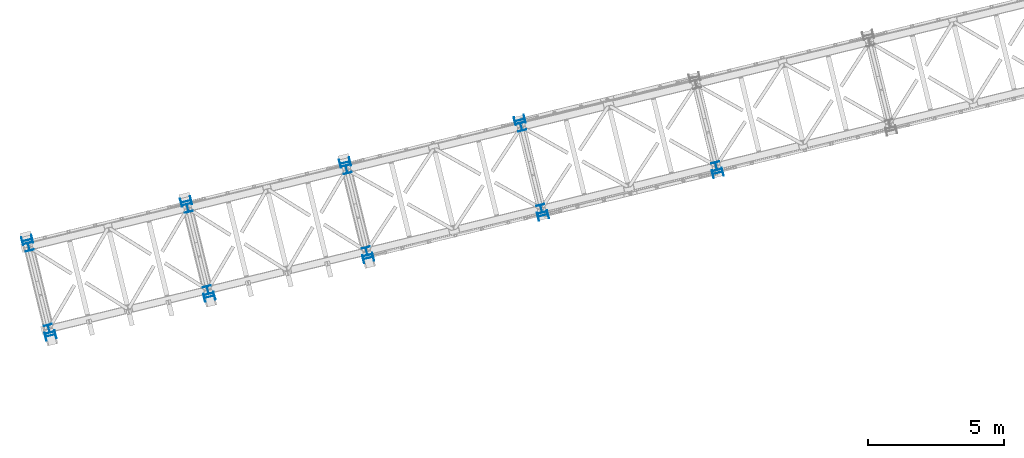
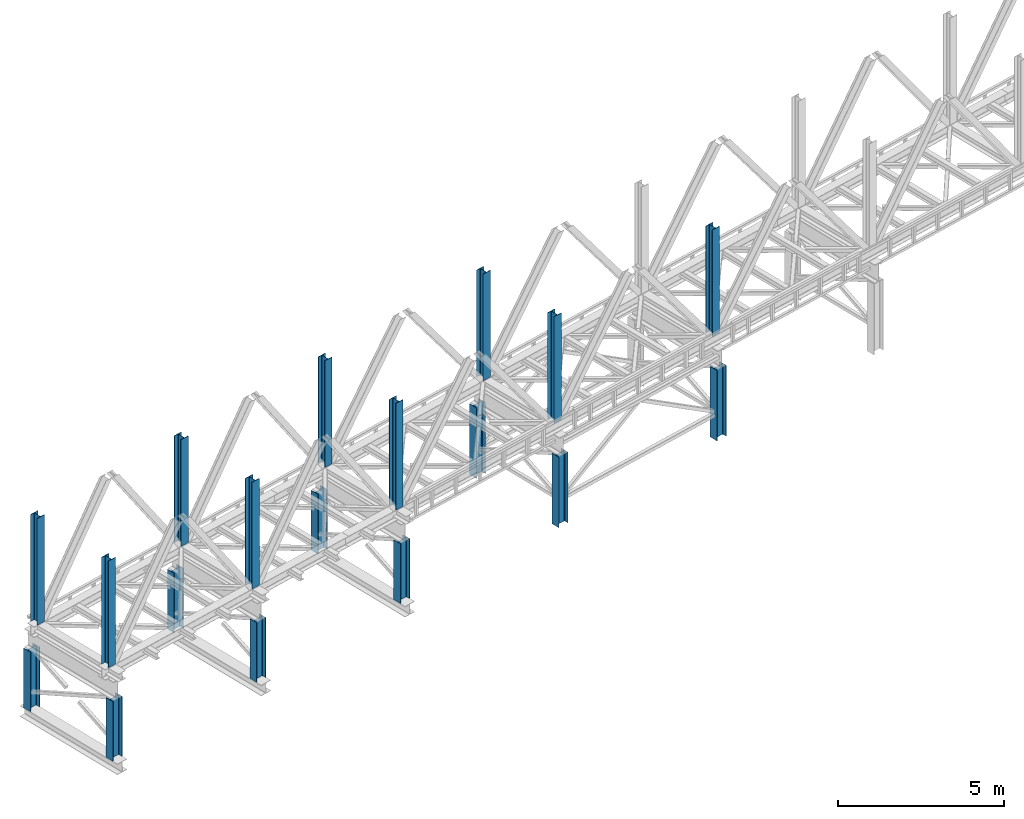
# One storey, part 1 of 93: 18 columns.
"""IFC4 building model written with IfcOpenShell, lengths in millimetres."""

from ifc_helpers import new_model, entity, si_unit, converted_unit, derived_unit, direction, frame, origin, place, context, subcontext, project, spatial, indexed_curve, outline, extrude, type_object, element, save


model = new_model("IFC4")

# Units and contexts
model_context = context("Model", 3, precision=0.01, world=origin(), true_north=direction((6.12303176911189e-17, 1.0)))
plan_context = context("Plan", 3, precision=0.01, world=origin(), true_north=direction((6.12303176911189e-17, 1.0)))
body_context = subcontext(model_context, "Body", "Model", "MODEL_VIEW")
ifc_project = project(units=[si_unit("LENGTHUNIT", "METRE", prefix="MILLI"), si_unit("AREAUNIT", "SQUARE_METRE"), si_unit("VOLUMEUNIT", "CUBIC_METRE"), converted_unit("PLANEANGLEUNIT", "DEGREE", entity("IfcRatioMeasure", 0.0174532925199433), si_unit("PLANEANGLEUNIT", "RADIAN"), dimensions=[0, 0, 0, 0, 0, 0, 0]), si_unit("MASSUNIT", "GRAM", prefix="KILO"), derived_unit("MASSDENSITYUNIT", [(si_unit("MASSUNIT", "GRAM", prefix="KILO"), 1), (si_unit("LENGTHUNIT", "METRE"), -3)]), derived_unit("MOMENTOFINERTIAUNIT", [(si_unit("LENGTHUNIT", "METRE"), 4)]), si_unit("TIMEUNIT", "SECOND"), si_unit("FREQUENCYUNIT", "HERTZ"), si_unit("THERMODYNAMICTEMPERATUREUNIT", "DEGREE_CELSIUS"), derived_unit("THERMALTRANSMITTANCEUNIT", [(si_unit("MASSUNIT", "GRAM", prefix="KILO"), 1), (si_unit("THERMODYNAMICTEMPERATUREUNIT", "KELVIN"), -1), (si_unit("TIMEUNIT", "SECOND"), -3)]), derived_unit("VOLUMETRICFLOWRATEUNIT", [(si_unit("LENGTHUNIT", "METRE"), 3), (si_unit("TIMEUNIT", "SECOND"), -1)]), derived_unit("MASSFLOWRATEUNIT", [(si_unit("MASSUNIT", "GRAM", prefix="KILO"), 1), (si_unit("TIMEUNIT", "SECOND"), -1)]), derived_unit("ROTATIONALFREQUENCYUNIT", [(si_unit("TIMEUNIT", "SECOND"), -1)]), si_unit("ELECTRICCURRENTUNIT", "AMPERE"), si_unit("ELECTRICVOLTAGEUNIT", "VOLT"), si_unit("POWERUNIT", "WATT"), si_unit("FORCEUNIT", "NEWTON", prefix="KILO"), si_unit("ILLUMINANCEUNIT", "LUX"), si_unit("LUMINOUSFLUXUNIT", "LUMEN"), si_unit("LUMINOUSINTENSITYUNIT", "CANDELA"), derived_unit("USERDEFINED", [(si_unit("MASSUNIT", "GRAM", prefix="KILO"), -1), (si_unit("LENGTHUNIT", "METRE"), -2), (si_unit("TIMEUNIT", "SECOND"), 3), (si_unit("LUMINOUSFLUXUNIT", "LUMEN"), 1)]), derived_unit("LINEARVELOCITYUNIT", [(si_unit("LENGTHUNIT", "METRE"), 1), (si_unit("TIMEUNIT", "SECOND"), -1)]), si_unit("PRESSUREUNIT", "PASCAL"), derived_unit("USERDEFINED", [(si_unit("LENGTHUNIT", "METRE"), -2), (si_unit("MASSUNIT", "GRAM", prefix="KILO"), 1), (si_unit("TIMEUNIT", "SECOND"), -2)]), derived_unit("LINEARFORCEUNIT", [(si_unit("MASSUNIT", "GRAM", prefix="KILO"), 1), (si_unit("LENGTHUNIT", "METRE"), 1), (si_unit("TIMEUNIT", "SECOND"), -2), (si_unit("LENGTHUNIT", "METRE"), -1)]), derived_unit("PLANARFORCEUNIT", [(si_unit("MASSUNIT", "GRAM", prefix="KILO"), 1), (si_unit("LENGTHUNIT", "METRE"), 1), (si_unit("TIMEUNIT", "SECOND"), -2), (si_unit("LENGTHUNIT", "METRE"), -2)])], contexts=[model_context, plan_context])

# Site, building, storey
site_placement = place(None, origin())
site = spatial("IfcSite", under=ifc_project, at=site_placement, CompositionType="ELEMENT")
building_placement = place(site_placement, origin())
building = spatial("IfcBuilding", under=site, at=building_placement, CompositionType="ELEMENT")
storey_placement = place(building_placement, frame((0.0, 0.0, 15900.0)))
storey = spatial("IfcBuildingStorey", under=building, at=storey_placement, CompositionType="ELEMENT", Elevation=15900.0)

# Columns
column_type_1 = type_object("IfcColumnType", PredefinedType="COLUMN")
column_1_placement = place(storey_placement, origin())
element("IfcColumn", 1, at=column_1_placement, inside=storey, type_object=column_type_1, ObjectType="Steel Column", PredefinedType="COLUMN", context=body_context, shape_type="SweptSolid", body=[
    extrude(outline(indexed_curve([(-196.000000000003, -149.999999999996), (-180.000000000004, -149.999999999996), (-179.999999999999, -27.7499999999967), (-178.325349715252, -19.3309644879636), (-173.556349186109, -12.1936508138919), (-166.419035512033, -7.42465028474881), (-157.999999999999, -5.74999999999698), (157.999999999996, -5.75000000000311), (166.419035512028, -7.42465028475528), (173.556349186106, -12.193650813901), (178.325349715245, -19.3309644879716), (180.000000000002, -27.7500000000052), (179.999999999998, -150.000000000004), (195.999999999997, -150.000000000005), (196.000000000003, 149.999999999995), (180.000000000003, 149.999999999995), (179.999999999999, 27.7499999999961), (178.325349715252, 19.3309644879631), (173.5563491861, 12.193650813893), (166.419035512032, 7.4246502847467), (157.999999999999, 5.74999999999646), (-157.999999999997, 5.75000000000206), (-166.419035512028, 7.4246502847537), (-173.556349186115, 12.1936508139025), (-178.325349715245, 19.3309644879711), (-180.000000000002, 27.7500000000047), (-179.999999999998, 150.000000000003), (-195.999999999997, 150.000000000004), (-196.000000000003, -149.999999999996)], self_intersect=False)), frame((-60216.4372865305, 2665.86311666468, 398.0), z_axis=(0.0, 0.0, 1.0), x_axis=(-0.971552058141468, -0.236826092990358, 0.0)), (0.0, 0.0, 1.0), 2197.00000000001),
])
column_type_2 = type_object("IfcColumnType", PredefinedType="COLUMN")
column_2_placement = place(storey_placement, origin())
element("IfcColumn", 2, at=column_2_placement, inside=storey, type_object=column_type_2, ObjectType="Steel Column", PredefinedType="COLUMN", context=body_context, shape_type="SweptSolid", body=[
    extrude(outline(indexed_curve([(-196.000000000006, -150.0), (-180.000000000007, -150.0), (-180.000000000007, -27.75), (-178.32534971526, -19.3309644879674), (-173.556349186108, -12.1936508138966), (-166.419035512041, -7.42465028475223), (-158.000000000007, -5.75000000000066), (157.999999999988, -5.74999999999533), (166.419035512028, -7.42465028474928), (173.556349186099, -12.1936508138922), (178.325349715238, -19.3309644879637), (179.999999999995, -27.7499999999967), (179.999999999995, -149.999999999996), (195.999999999994, -149.999999999996), (195.99999999999, 150.000000000004), (179.99999999999, 150.000000000003), (179.99999999999, 27.7500000000041), (178.325349715243, 19.3309644879715), (173.5563491861, 12.1936508138987), (166.419035512024, 7.42465028475633), (157.99999999999, 5.75000000000371), (-158.000000000005, 5.75000000000049), (-166.419035512036, 7.42465028475133), (-173.556349186115, 12.1936508138973), (-178.325349715254, 19.3309644879689), (-180.000000000012, 27.7500000000019), (-180.000000000012, 150.0), (-196.000000000011, 150.0), (-196.000000000006, -150.0)], self_intersect=False)), frame((-61069.0112212957, 6163.45052597398, 398.0), z_axis=(0.0, 0.0, 1.0), x_axis=(-0.971552058141476, -0.236826092990326, 0.0)), (0.0, 0.0, 1.0), 2197.0),
])
column_type_3 = type_object("IfcColumnType", PredefinedType="COLUMN")
column_3_placement = place(storey_placement, origin())
element("IfcColumn", 3, at=column_3_placement, inside=storey, type_object=column_type_3, ObjectType="Steel Column", PredefinedType="COLUMN", context=body_context, shape_type="SweptSolid", body=[
    extrude(outline(indexed_curve([(-196.000000000003, -149.999999999995), (-180.000000000003, -149.999999999995), (-179.999999999999, -27.7499999999956), (-178.325349715252, -19.3309644879631), (-173.556349186109, -12.1936508138909), (-166.419035512032, -7.42465028474775), (-157.999999999999, -5.74999999999646), (158.000000000005, -5.75000000000358), (166.419035512028, -7.42465028475423), (173.556349186107, -12.1936508138999), (178.325349715246, -19.3309644879706), (180.000000000003, -27.7500000000042), (179.999999999998, -150.000000000003), (195.999999999998, -150.000000000003), (196.000000000003, 149.999999999996), (180.000000000004, 149.999999999996), (179.999999999999, 27.7499999999972), (178.325349715252, 19.3309644879641), (173.5563491861, 12.193650813894), (166.419035512032, 7.42465028474775), (157.999999999999, 5.74999999999751), (-157.999999999996, 5.75000000000258), (-166.419035512028, 7.42465028475423), (-173.556349186106, 12.1936508139015), (-178.325349715245, 19.3309644879721), (-180.000000000002, 27.7500000000047), (-179.999999999998, 150.000000000004), (-195.999999999997, 150.000000000004), (-196.000000000003, -149.999999999995)], self_intersect=False)), frame((-54387.1249376817, 4086.8196746067, 398.0), z_axis=(0.0, 0.0, 1.0), x_axis=(-0.971552058141468, -0.236826092990358, 0.0)), (0.0, 0.0, 1.0), 2197.00000000001),
])
column_type_4 = type_object("IfcColumnType", PredefinedType="COLUMN")
column_4_placement = place(storey_placement, origin())
element("IfcColumn", 4, at=column_4_placement, inside=storey, type_object=column_type_4, ObjectType="Steel Column", PredefinedType="COLUMN", context=body_context, shape_type="SweptSolid", body=[
    extrude(outline(indexed_curve([(-195.999999999982, -150.000000000009), (-179.999999999982, -150.000000000008), (-179.999999999982, -27.7500000000083), (-178.325349715235, -19.3309644879757), (-173.556349186092, -12.1936508139028), (-166.419035512016, -7.42465028476049), (-157.999999999982, -5.75000000000891), (158.000000000021, -5.75000000000564), (166.419035512044, -7.42465028475549), (173.556349186123, -12.1936508139004), (178.325349715262, -19.330964487972), (180.00000000002, -27.750000000005), (180.000000000019, -150.000000000004), (196.000000000019, -150.000000000004), (196.000000000014, 149.999999999996), (180.000000000015, 149.999999999995), (180.000000000015, 27.7499999999959), (178.325349715268, 19.3309644879632), (173.556349186116, 12.1936508138925), (166.419035512049, 7.42465028474807), (158.000000000015, 5.74999999999545), (-157.999999999981, 5.74999999998907), (-166.41903551202, 7.42465028474407), (-173.556349186091, 12.193650813888), (-178.325349715238, 19.3309644879605), (-179.999999999987, 27.7499999999926), (-179.999999999987, 149.999999999991), (-195.999999999986, 149.999999999991), (-195.999999999982, -150.000000000009)], self_intersect=False)), frame((-55239.6988724469, 7584.407083916, 398.0), z_axis=(0.0, 0.0, 1.0), x_axis=(-0.971552058141476, -0.236826092990326, 0.0)), (0.0, 0.0, 1.0), 2197.0),
])
column_type_5 = type_object("IfcColumnType", PredefinedType="COLUMN")
column_5_placement = place(storey_placement, origin())
element("IfcColumn", 5, at=column_5_placement, inside=storey, type_object=column_type_5, ObjectType="Steel Column", PredefinedType="COLUMN", context=body_context, shape_type="SweptSolid", body=[
    extrude(outline(indexed_curve([(-196.000000000008, -149.99999999999), (-180.000000000009, -149.99999999999), (-180.0, -27.7499999999913), (-178.325349715253, -19.3309644879588), (-173.556349186109, -12.1936508138862), (-166.419035512033, -7.42465028474332), (-157.999999999999, -5.74999999999335), (157.999999999996, -5.75000000000884), (166.419035512027, -7.42465028476128), (173.556349186106, -12.1936508139067), (178.325349715245, -19.3309644879775), (179.999999999993, -27.7500000000096), (179.999999999993, -150.000000000012), (195.999999999992, -150.000000000012), (196.000000000008, 149.999999999988), (180.000000000008, 149.999999999988), (180.0, 27.7499999999892), (178.325349715253, 19.3309644879567), (173.556349186109, 12.1936508138852), (166.419035512032, 7.42465028474122), (157.999999999998, 5.74999999999019), (-157.999999999996, 5.75000000000779), (-166.419035512028, 7.42465028475707), (-173.556349186106, 12.1936508139056), (-178.325349715245, 19.3309644879764), (-180.000000000002, 27.7500000000106), (-179.999999999993, 150.000000000011), (-195.999999999993, 150.00000000001), (-196.000000000008, -149.99999999999)], self_intersect=False)), frame((-48557.8125888328, 5507.77623254873, 398.0), z_axis=(0.0, 0.0, 1.0), x_axis=(-0.97155205814146, -0.23682609299039, 0.0)), (0.0, 0.0, 1.0), 2197.00000000001),
])
column_type_6 = type_object("IfcColumnType", PredefinedType="COLUMN")
column_6_placement = place(storey_placement, origin())
element("IfcColumn", 6, at=column_6_placement, inside=storey, type_object=column_type_6, ObjectType="Steel Column", PredefinedType="COLUMN", context=body_context, shape_type="SweptSolid", body=[
    extrude(outline(indexed_curve([(-196.000000000007, -150.000000000001), (-180.000000000007, -150.000000000001), (-180.000000000007, -27.7500000000011), (-178.32534971526, -19.3309644879685), (-173.556349186117, -12.1936508138956), (-166.419035512041, -7.42465028475328), (-158.000000000007, -5.75000000000066), (157.999999999988, -5.74999999999744), (166.419035512019, -7.42465028474828), (173.556349186098, -12.1936508138932), (178.325349715237, -19.3309644879648), (179.999999999995, -27.7499999999967), (179.999999999994, -149.999999999997), (195.999999999994, -149.999999999997), (195.999999999989, 150.000000000002), (179.99999999999, 150.000000000003), (179.99999999999, 27.7500000000041), (178.325349715234, 19.3309644879725), (173.556349186091, 12.1936508138997), (166.419035512024, 7.42465028475528), (157.99999999999, 5.75000000000266), (-158.000000000005, 5.74999999999838), (-166.419035512045, 7.42465028475233), (-173.556349186116, 12.1936508138963), (-178.325349715254, 19.3309644879678), (-180.000000000012, 27.7499999999998), (-180.000000000012, 149.999999999999), (-196.000000000011, 149.999999999999), (-196.000000000007, -150.000000000001)], self_intersect=False)), frame((-49410.386523598, 9005.36364185803, 398.0), z_axis=(0.0, 0.0, 1.0), x_axis=(-0.971552058141476, -0.236826092990326, 0.0)), (0.0, 0.0, 1.0), 2197.0),
])
column_type_7 = type_object("IfcColumnType", PredefinedType="COLUMN")
column_7_placement = place(storey_placement, origin())
element("IfcColumn", 7, at=column_7_placement, inside=storey, type_object=column_type_7, ObjectType="Steel Column", PredefinedType="COLUMN", context=body_context, shape_type="SweptSolid", body=[
    extrude(outline(indexed_curve([(-196.000000000007, -150.000000000002), (-180.000000000008, -150.000000000002), (-180.000000000007, -27.7500000000032), (-178.325349715252, -19.3309644879715), (-173.556349186109, -12.1936508138987), (-166.419035512041, -7.42465028475433), (-158.000000000008, -5.75000000000275), (157.999999999996, -5.75000000000055), (166.419035512027, -7.42465028475138), (173.556349186098, -12.1936508138953), (178.325349715237, -19.3309644879658), (179.999999999994, -27.7499999999989), (179.999999999994, -149.999999999998), (195.999999999993, -149.999999999999), (195.999999999989, 150.000000000001), (179.99999999999, 150.000000000002), (179.999999999998, 27.75), (178.325349715242, 19.3309644879683), (173.556349186099, 12.1936508138955), (166.419035512023, 7.42465028475317), (157.999999999989, 5.7500000000016), (-158.000000000014, 5.74999999999939), (-166.419035512037, 7.42465028474713), (-173.556349186116, 12.1936508138931), (-178.325349715264, 19.3309644879657), (-180.000000000013, 27.7499999999966), (-180.000000000012, 149.999999999997), (-196.000000000011, 149.999999999998), (-196.000000000007, -150.000000000002)], self_intersect=False)), frame((-42145.5637561598, 7070.82982162869, -1.99240972102241), z_axis=(0.0, 0.0, 1.0), x_axis=(-0.971552058141476, -0.236826092990326, 0.0)), (0.0, 0.0, 1.0), 2595.99999999999),
])
column_type_8 = type_object("IfcColumnType", PredefinedType="COLUMN")
column_8_placement = place(storey_placement, origin())
element("IfcColumn", 8, at=column_8_placement, inside=storey, type_object=column_type_8, ObjectType="Steel Column", PredefinedType="COLUMN", context=body_context, shape_type="SweptSolid", body=[
    extrude(outline(indexed_curve([(-195.999999999981, -150.000000000007), (-179.999999999982, -150.000000000007), (-179.999999999982, -27.7500000000072), (-178.325349715235, -19.3309644879746), (-173.556349186092, -12.1936508139018), (-166.419035512016, -7.42465028475944), (-157.999999999982, -5.75000000000681), (158.000000000021, -5.75000000000564), (166.419035512045, -7.42465028475443), (173.556349186124, -12.1936508138994), (178.325349715262, -19.330964487972), (180.000000000011, -27.7500000000029), (180.00000000002, -150.000000000003), (196.000000000019, -150.000000000003), (196.000000000015, 149.999999999997), (180.000000000015, 149.999999999995), (180.000000000015, 27.7499999999969), (178.32534971526, 19.3309644879663), (173.556349186125, 12.1936508138914), (166.419035512049, 7.42465028474913), (158.000000000015, 5.7499999999965), (-157.99999999998, 5.74999999999118), (-166.41903551202, 7.42465028474617), (-173.556349186091, 12.193650813887), (-178.32534971523, 19.3309644879595), (-179.999999999987, 27.7499999999926), (-179.999999999987, 149.999999999993), (-195.999999999986, 149.999999999993), (-195.999999999981, -150.000000000007)], self_intersect=False)), frame((-42998.1429398643, 10568.4158555943, -2.0), z_axis=(0.0, 0.0, 1.0), x_axis=(-0.971552058141476, -0.236826092990326, 0.0)), (0.0, 0.0, 1.0), 2597.00000000003),
])
column_type_9 = type_object("IfcColumnType", PredefinedType="COLUMN")
column_9_placement = place(storey_placement, origin())
element("IfcColumn", 9, at=column_9_placement, inside=storey, type_object=column_type_9, ObjectType="Steel Column", PredefinedType="COLUMN", context=body_context, shape_type="SweptSolid", body=[
    extrude(outline(indexed_curve([(-196.000000000007, -150.000000000002), (-179.999999999999, -150.000000000002), (-180.000000000003, -27.7500000000015), (-178.325349715252, -19.3309644879699), (-173.556349186109, -12.1936508138971), (-166.419035512037, -7.4246502847527), (-158.000000000007, -5.75000000000118), (157.999999999996, -5.74999999999896), (166.419035512028, -7.42465028475089), (173.556349186103, -12.1936508138948), (178.325349715246, -19.3309644879664), (179.999999999995, -27.7499999999984), (179.999999999994, -149.999999999999), (196.000000000002, -149.999999999999), (195.999999999999, 150.000000000002), (179.99999999999, 150.000000000002), (179.999999999994, 27.7500000000014), (178.325349715243, 19.3309644879698), (173.5563491861, 12.193650813897), (166.419035512028, 7.42465028475265), (157.999999999994, 5.7500000000011), (-158.000000000005, 5.74999999999997), (-166.419035512036, 7.42465028475294), (-173.556349186107, 12.1936508138948), (-178.325349715254, 19.3309644879684), (-180.000000000008, 27.7499999999994), (-180.000000000002, 150.000000000001), (-196.000000000011, 149.999999999999), (-196.000000000007, -150.000000000002)], self_intersect=False)), frame((-35733.3201724261, 8633.88203536492, -1.99240972102241), z_axis=(0.0, 0.0, 1.0), x_axis=(-0.971552058141475, -0.23682609299033, 0.0)), (0.0, 0.0, 1.0), 2596.99999999999),
])
column_type_10 = type_object("IfcColumnType", PredefinedType="COLUMN")
column_10_placement = place(storey_placement, origin())
element("IfcColumn", 10, at=column_10_placement, inside=storey, type_object=column_type_10, ObjectType="Steel Column", PredefinedType="COLUMN", context=body_context, shape_type="SweptSolid", body=[
    extrude(outline(indexed_curve([(-149.999999999947, -150.00000000004), (-134.499999999948, -150.00000000004), (-134.499999999989, -23.000000000035), (-133.129831585195, -16.1116982174633), (-129.227922061352, -10.2720779386778), (-123.388301782567, -6.37016841483106), (-116.499999999995, -5.00000000002753), (116.500000000005, -4.99999999995134), (123.388301782576, -6.37016841475037), (129.227922061364, -10.2720779385883), (133.129831585211, -16.1116982173765), (134.500000000009, -22.9999999999507), (134.500000000052, -149.999999999947), (150.000000000053, -149.999999999939), (149.999999999952, 150.000000000057), (134.499999999953, 150.000000000057), (134.499999999994, 23.0000000000515), (133.1298315852, 16.11169821748), (129.227922061357, 10.2720779386945), (123.388301782573, 6.37016841484763), (116.5, 5.0000000000441), (-116.499999999999, 4.99999999996792), (-123.388301782572, 6.3701684147584), (-129.227922061359, 10.272077938605), (-133.129831585207, 16.1116982173846), (-134.500000000006, 22.9999999999588), (-134.500000000047, 149.999999999964), (-150.000000000048, 149.999999999956), (-149.999999999947, -150.00000000004)], self_intersect=False)), frame((-60275.6438097781, 2908.75113120005, 3685.0), z_axis=(0.0, 0.0, 1.0), x_axis=(-0.236826092990013, 0.971552058141552, 0.0)), (0.0, 0.0, 1.0), 3931.00000000001),
])
column_type_11 = type_object("IfcColumnType", PredefinedType="COLUMN")
column_11_placement = place(storey_placement, origin())
element("IfcColumn", 11, at=column_11_placement, inside=storey, type_object=column_type_11, ObjectType="Steel Column", PredefinedType="COLUMN", context=body_context, shape_type="SweptSolid", body=[
    extrude(outline(indexed_curve([(-149.999999999951, -150.000000000048), (-134.499999999952, -150.000000000048), (-134.499999999993, -23.0000000000429), (-133.129831585199, -16.1116982174712), (-129.227922061356, -10.2720779386857), (-123.388301782572, -6.37016841483897), (-116.499999999999, -5.00000000003544), (116.5, -4.99999999995924), (123.388301782572, -6.37016841475827), (129.22792206136, -10.2720779385963), (133.129831585206, -16.1116982173844), (134.500000000005, -22.9999999999586), (134.500000000048, -149.999999999955), (150.000000000049, -149.999999999947), (149.999999999948, 150.000000000049), (134.499999999949, 150.000000000049), (134.49999999999, 23.0000000000436), (133.129831585196, 16.111698217472), (129.227922061353, 10.2720779386865), (123.388301782569, 6.37016841483961), (116.499999999996, 5.00000000003607), (-116.500000000003, 4.99999999995975), (-123.388301782576, 6.37016841475036), (-129.227922061362, 10.2720779385968), (-133.129831585211, 16.1116982173766), (-134.500000000009, 22.9999999999507), (-134.500000000048, 149.999999999964), (-150.000000000052, 149.999999999948), (-149.999999999951, -150.000000000048)], self_intersect=False)), frame((-54446.3314609293, 4329.70768914207, 3685.0), z_axis=(0.0, 0.0, 1.0), x_axis=(-0.236826092990013, 0.971552058141552, 0.0)), (0.0, 0.0, 1.0), 3931.00000000001),
])
column_type_12 = type_object("IfcColumnType", PredefinedType="COLUMN")
column_12_placement = place(storey_placement, origin())
element("IfcColumn", 12, at=column_12_placement, inside=storey, type_object=column_type_12, ObjectType="Steel Column", PredefinedType="COLUMN", context=body_context, shape_type="SweptSolid", body=[
    extrude(outline(indexed_curve([(-150.000000000031, -149.999999999977), (-134.50000000003, -149.999999999977), (-134.500000000005, -22.9999999999802), (-133.129831585207, -16.1116982174091), (-129.227922061359, -10.2720779386173), (-123.388301782573, -6.37016841477337), (-116.500000000001, -4.99999999998207), (116.499999999999, -5.00000000003072), (123.38830178257, -6.37016841482463), (129.227922061355, -10.2720779386745), (133.1298315852, -16.1116982174562), (134.499999999995, -23.0000000000312), (134.49999999997, -150.000000000028), (149.999999999969, -150.000000000036), (150.00000000003, 149.999999999968), (134.500000000029, 149.999999999968), (134.500000000006, 22.999999999971), (133.129831585206, 16.1116982174004), (129.227922061359, 10.2720779386083), (123.388301782573, 6.37016841477337), (116.5, 4.99999999997339), (-116.500000000001, 5.00000000001338), (-123.388301782574, 6.3701684148078), (-129.227922061357, 10.2720779386571), (-133.129831585203, 16.1116982174391), (-134.499999999998, 23.0000000000141), (-134.499999999969, 150.000000000027), (-149.99999999997, 150.000000000027), (-150.000000000031, -149.999999999977)], self_intersect=False)), frame((-48617.0191120804, 5750.66424708409, 3685.0), z_axis=(0.0, 0.0, 1.0), x_axis=(-0.236826092990533, 0.971552058141425, 0.0)), (0.0, 0.0, 1.0), 3931.00000000001),
])
column_type_13 = type_object("IfcColumnType", PredefinedType="COLUMN")
column_13_placement = place(storey_placement, origin())
element("IfcColumn", 13, at=column_13_placement, inside=storey, type_object=column_type_13, ObjectType="Steel Column", PredefinedType="COLUMN", context=body_context, shape_type="SweptSolid", body=[
    extrude(outline(indexed_curve([(-150.000000000024, -149.999999999952), (-134.500000000023, -149.999999999952), (-134.499999999998, -22.9999999999549), (-133.1298315852, -16.1116982173841), (-129.227922061354, -10.2720779386007), (-123.388301782568, -6.3701684147568), (-116.499999999994, -4.99999999995708), (116.500000000005, -5.00000000000547), (123.388301782577, -6.37016841479963), (129.227922061363, -10.2720779386495), (133.129831585206, -16.1116982174396), (134.500000000003, -23.0000000000062), (134.499999999975, -150.000000000011), (149.999999999976, -150.000000000011), (150.000000000036, 149.999999999985), (134.500000000036, 149.999999999993), (134.500000000012, 22.9999999999962), (133.129831585213, 16.1116982174254), (129.227922061365, 10.2720779386336), (123.388301782578, 6.37016841478995), (116.500000000008, 4.99999999999839), (-116.499999999994, 5.00000000003837), (-123.388301782566, 6.37016841483253), (-129.227922061352, 10.2720779386826), (-133.129831585197, 16.1116982174643), (-134.499999999989, 23.0000000000475), (-134.499999999963, 150.000000000044), (-149.999999999965, 150.000000000044), (-150.000000000024, -149.999999999952)], self_intersect=False)), frame((-42204.7702573512, 7313.71774568122, 3685.0), z_axis=(0.0, 0.0, 1.0), x_axis=(-0.236826092990533, 0.971552058141425, 0.0)), (0.0, 0.0, 1.0), 3931.00000000001),
])
column_type_14 = type_object("IfcColumnType", PredefinedType="COLUMN")
column_14_placement = place(storey_placement, origin())
element("IfcColumn", 14, at=column_14_placement, inside=storey, type_object=column_type_14, ObjectType="Steel Column", PredefinedType="COLUMN", context=body_context, shape_type="SweptSolid", body=[
    extrude(outline(indexed_curve([(-149.99999999999, -150.000000000002), (-134.499999999991, -150.000000000002), (-134.499999999998, -23.0000000000013), (-133.129831585201, -16.1116982174301), (-129.227922061357, -10.2720779386457), (-123.388301782571, -6.37016841480061), (-116.499999999998, -4.99999999999888), (116.500000000001, -4.99999999998789), (123.388301782573, -6.37016841478476), (129.22792206136, -10.2720779386286), (133.129831585204, -16.1116982174178), (134.500000000002, -22.9999999999882), (134.500000000009, -149.999999999989), (150.000000000008, -149.999999999989), (149.999999999993, 150.000000000015), (134.499999999992, 150.000000000011), (134.5, 23.0000000000097), (133.129831585203, 16.1116982174385), (129.227922061359, 10.2720779386541), (123.388301782573, 6.37016841480903), (116.5, 5.00000000000729), (-116.499999999999, 5.00000000000078), (-123.388301782568, 6.37016841479687), (-129.227922061358, 10.2720779386415), (-133.129831585203, 16.111698217422), (-134.5, 23.0000000000011), (-134.500000000006, 150.000000000002), (-150.000000000007, 149.999999999998), (-149.99999999999, -150.000000000002)], self_intersect=False)), frame((-35792.5266736175, 8876.76995941745, 3685.0), z_axis=(0.0, 0.0, 1.0), x_axis=(-0.236826092990285, 0.971552058141486, 0.0)), (0.0, 0.0, 1.0), 3931.00000000001),
])
column_type_15 = type_object("IfcColumnType", PredefinedType="COLUMN")
column_15_placement = place(storey_placement, origin())
element("IfcColumn", 15, at=column_15_placement, inside=storey, type_object=column_type_15, ObjectType="Steel Column", PredefinedType="COLUMN", context=body_context, shape_type="SweptSolid", body=[
    extrude(outline(indexed_curve([(-149.999999999947, -150.000000000039), (-134.499999999949, -150.000000000039), (-134.499999999988, -23.0000000000341), (-133.129831585195, -16.1116982174623), (-129.227922061351, -10.2720779386771), (-123.388301782566, -6.37016841483042), (-116.499999999994, -5.00000000002682), (116.500000000006, -4.99999999995256), (123.388301782576, -6.37016841475152), (129.227922061366, -10.2720779385899), (133.129831585212, -16.1116982173779), (134.50000000001, -22.999999999952), (134.500000000052, -149.999999999949), (150.000000000054, -149.999999999941), (149.999999999955, 150.000000000055), (134.499999999955, 150.000000000055), (134.499999999996, 23.0000000000502), (133.129831585202, 16.1116982174784), (129.227922061359, 10.2720779386929), (123.388301782573, 6.37016841484648), (116.500000000001, 5.00000000004288), (-116.499999999996, 4.99999999997705), (-123.388301782569, 6.37016841476758), (-129.227922061358, 10.2720779386057), (-133.129831585205, 16.111698217394), (-134.500000000003, 22.9999999999683), (-134.500000000045, 149.999999999965), (-150.000000000047, 149.999999999957), (-149.999999999947, -150.000000000039)], self_intersect=False)), frame((-61009.8046980481, 5920.56251143861, 3685.0), z_axis=(0.0, 0.0, 1.0), x_axis=(-0.236826092990021, 0.97155205814155, 0.0)), (0.0, 0.0, 1.0), 3931.00000000001),
])
column_type_16 = type_object("IfcColumnType", PredefinedType="COLUMN")
column_16_placement = place(storey_placement, origin())
element("IfcColumn", 16, at=column_16_placement, inside=storey, type_object=column_type_16, ObjectType="Steel Column", PredefinedType="COLUMN", context=body_context, shape_type="SweptSolid", body=[
    extrude(outline(indexed_curve([(-149.999999999947, -150.000000000041), (-134.499999999948, -150.000000000041), (-134.49999999999, -23.0000000000358), (-133.129831585195, -16.1116982174643), (-129.227922061353, -10.2720779386788), (-123.388301782568, -6.37016841483195), (-116.499999999996, -5.00000000002824), (116.500000000004, -4.99999999995012), (123.388301782574, -6.37016841474896), (129.227922061364, -10.2720779385872), (133.12983158521, -16.1116982173752), (134.500000000008, -22.9999999999492), (134.500000000053, -149.999999999946), (150.000000000054, -149.999999999938), (149.999999999951, 150.000000000058), (134.499999999951, 150.000000000058), (134.499999999993, 23.0000000000529), (133.1298315852, 16.1116982174811), (129.227922061357, 10.2720779386956), (123.388301782571, 6.37016841484905), (116.499999999999, 5.00000000004533), (-116.499999999998, 4.99999999997563), (-123.388301782571, 6.37016841476605), (-129.22792206136, 10.272077938604), (-133.129831585207, 16.1116982173923), (-134.500000000006, 22.9999999999666), (-134.500000000047, 149.999999999972), (-150.00000000005, 149.999999999955), (-149.999999999947, -150.000000000041)], self_intersect=False)), frame((-55180.4923491993, 7341.51906938064, 3685.0), z_axis=(0.0, 0.0, 1.0), x_axis=(-0.236826092990005, 0.971552058141554, 0.0)), (0.0, 0.0, 1.0), 3931.00000000001),
])
column_type_17 = type_object("IfcColumnType", PredefinedType="COLUMN")
column_17_placement = place(storey_placement, origin())
element("IfcColumn", 17, at=column_17_placement, inside=storey, type_object=column_type_17, ObjectType="Steel Column", PredefinedType="COLUMN", context=body_context, shape_type="SweptSolid", body=[
    extrude(outline(indexed_curve([(-149.999999999948, -150.000000000059), (-134.499999999949, -150.000000000059), (-134.499999999992, -23.0000000000621), (-133.129831585198, -16.1116982174903), (-129.227922061353, -10.2720779386966), (-123.388301782569, -6.37016841484955), (-116.499999999998, -5.00000000005451), (116.500000000002, -4.99999999997639), (123.388301782573, -6.37016841476656), (129.227922061362, -10.2720779386135), (133.12983158521, -16.1116982173931), (134.500000000009, -22.9999999999673), (134.500000000052, -149.999999999964), (150.000000000051, -149.999999999964), (149.99999999995, 150.00000000004), (134.499999999948, 150.000000000032), (134.499999999993, 23.0000000000351), (133.129831585199, 16.1116982174635), (129.227922061355, 10.2720779386693), (123.388301782571, 6.37016841483118), (116.499999999999, 5.00000000002747), (-116.500000000001, 4.99999999994961), (-123.388301782575, 6.37016841474029), (-129.227922061362, 10.2720779385778), (-133.12983158521, 16.1116982173663), (-134.500000000009, 22.9999999999406), (-134.50000000005, 149.999999999946), (-150.000000000051, 149.999999999937), (-149.999999999948, -150.000000000059)], self_intersect=False)), frame((-49351.1800003505, 8762.47562732266, 3685.0), z_axis=(0.0, 0.0, 1.0), x_axis=(-0.236826092990005, 0.971552058141554, 0.0)), (0.0, 0.0, 1.0), 3931.00000000001),
])
column_type_18 = type_object("IfcColumnType", PredefinedType="COLUMN")
column_18_placement = place(storey_placement, origin())
element("IfcColumn", 18, at=column_18_placement, inside=storey, type_object=column_type_18, ObjectType="Steel Column", PredefinedType="COLUMN", context=body_context, shape_type="SweptSolid", body=[
    extrude(outline(indexed_curve([(-150.00000000003, -149.999999999955), (-134.500000000031, -149.999999999955), (-134.5, -22.9999999999591), (-133.129831585202, -16.1116982173883), (-129.227922061357, -10.2720779386048), (-123.38830178257, -6.37016841476112), (-116.499999999996, -4.99999999996163), (116.500000000004, -5.00000000001801), (123.388301782576, -6.3701684148124), (129.22792206136, -10.2720779386622), (133.129831585203, -16.1116982174524), (134.5, -23.0000000000191), (134.499999999969, -150.000000000024), (149.99999999997, -150.000000000025), (150.000000000041, 149.999999999971), (134.500000000039, 149.99999999998), (134.500000000011, 22.9999999999833), (133.129831585212, 16.1116982174126), (129.227922061365, 10.2720779386206), (123.388301782577, 6.37016841477745), (116.500000000007, 4.99999999998585), (-116.499999999996, 5.00000000004274), (-123.388301782567, 6.37016841483714), (-129.227922061354, 10.2720779386785), (-133.129831585197, 16.1116982174688), (-134.499999999987, 23.0000000000517), (-134.499999999961, 150.00000000004), (-149.999999999962, 150.000000000041), (-150.00000000003, -149.999999999955)], self_intersect=False)), frame((-42938.9311456213, 10325.5291259198, 3685.0), z_axis=(0.0, 0.0, 1.0), x_axis=(-0.236826092990565, 0.971552058141418, 0.0)), (0.0, 0.0, 1.0), 3931.00000000001),
])

save(model, "model.ifc")
